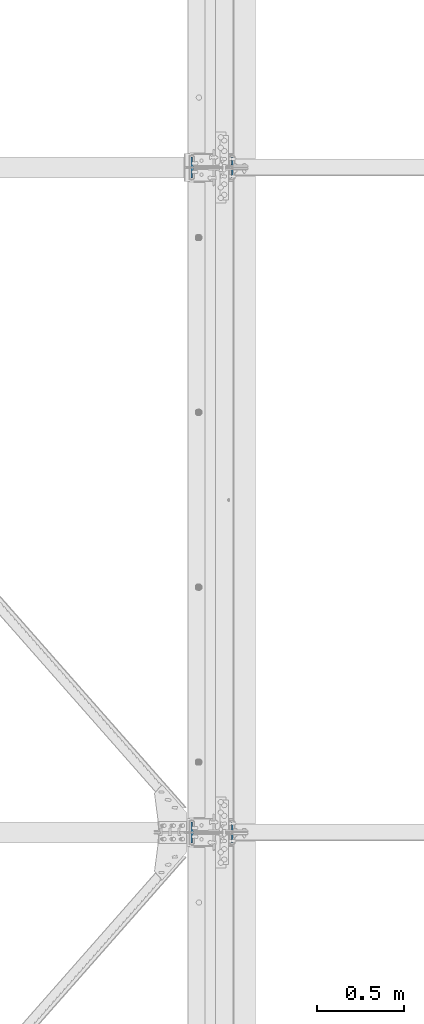
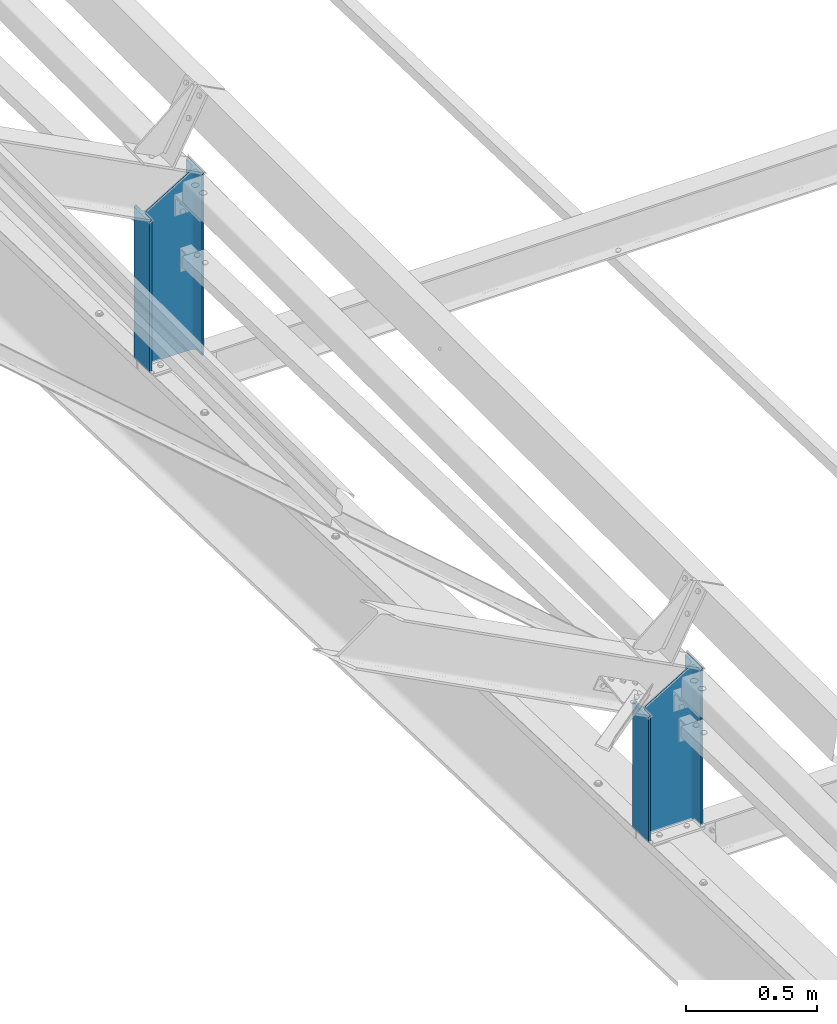
# One storey, part 31 of 496: 2 columns, 2 elements without a shape of their own.
"""IFC2X3 building model written with IfcOpenShell, lengths in millimetres."""

from ifc_helpers import new_model, si_unit, frame, origin_with_axes, origin_2d_with_axis, place, context, subcontext, project, spatial, i_section, extrude, clip, halfspace, material, type_object, element, aggregate, save


model = new_model("IFC2X3")

# Units and contexts
model_context = context("Model", 3, precision=1e-05, world=origin_with_axes())
body_context = subcontext(model_context, "Body", "Model", "MODEL_VIEW")
ifc_project = project(units=[si_unit("LENGTHUNIT", "METRE", prefix="MILLI"), si_unit("AREAUNIT", "SQUARE_METRE"), si_unit("VOLUMEUNIT", "CUBIC_METRE"), si_unit("MASSUNIT", "GRAM", prefix="KILO"), si_unit("TIMEUNIT", "SECOND"), si_unit("PLANEANGLEUNIT", "RADIAN"), si_unit("SOLIDANGLEUNIT", "STERADIAN"), si_unit("THERMODYNAMICTEMPERATUREUNIT", "DEGREE_CELSIUS"), si_unit("LUMINOUSINTENSITYUNIT", "LUMEN")], contexts=[model_context])

# Site, building, storey
site_placement = place(None, origin_with_axes())
site = spatial("IfcSite", under=ifc_project, at=site_placement, CompositionType="ELEMENT")
building_placement = place(site_placement, origin_with_axes())
building = spatial("IfcBuilding", under=site, at=building_placement, Name="Undefined", CompositionType="ELEMENT")
storey_placement = place(building_placement, origin_with_axes())
storey = spatial("IfcBuildingStorey", under=building, at=storey_placement, Name="Undefined", CompositionType="ELEMENT", Elevation=0.0)

# Assembly, column
assembly_1_placement = place(storey_placement, origin_with_axes())
assembly_1 = element("IfcElementAssembly", 1, at=assembly_1_placement, inside=storey, Name="TRAVERSE SHED", AssemblyPlace="NOTDEFINED", PredefinedType="NOTDEFINED")
ifc_material = material(Name="Undefined/S275-E28")
column_type = type_object("IfcColumnType", Name="IPE240", PredefinedType="NOTDEFINED")
column_1_placement = place(assembly_1_placement, frame((19550.0, 11400.0, 7691.74056786914), z_axis=(0.0, 0.0, 1.0), x_axis=(-1.0, 0.0, 0.0)))
column_1 = element("IfcColumn", 2, at=column_1_placement, type_object=column_type, material=ifc_material, Name="TRAVERSE SHED", ObjectType="IPE240", context=body_context, shape_type="Clipping", body=[
    clip(clip(extrude(i_section(OverallWidth=120.0, OverallDepth=240.0, WebThickness=6.199999809, FlangeThickness=9.800000191, FilletRadius=15.0, at=origin_2d_with_axis()), frame((0.0, 0.0, 860.890403333867), z_axis=(0.0, 0.0, -1.0), x_axis=(0.0, 1.0, 0.0)), (0.0, 0.0, 1.0), 926.17), halfspace(frame((-120.000000919932, 7600.0, 858.259434020199), z_axis=(0.517914825899091, 0.0, 0.855432190833332), x_axis=(0.0, 1.0, 0.0)), False)), halfspace(frame((0.0, -74.9626762494518, 7.64961930845766), z_axis=(0.0, 0.031410477145298, -0.999506569225788), x_axis=(1.0, 0.0, 0.0)), False)),
])
aggregate(assembly_1, [column_1])

assembly_2_placement = place(storey_placement, origin_with_axes())
assembly_2 = element("IfcElementAssembly", 3, at=assembly_2_placement, inside=storey, Name="TRAVERSE SHED", AssemblyPlace="NOTDEFINED", PredefinedType="NOTDEFINED")
column_2_placement = place(assembly_2_placement, frame((19550.0, 7600.0, 7811.1603785789), z_axis=(0.0, 0.0, 1.0), x_axis=(-1.0, 0.0, 0.0)))
column_2 = element("IfcColumn", 4, at=column_2_placement, type_object=column_type, material=ifc_material, Name="TRAVERSE SHED", ObjectType="IPE240", context=body_context, shape_type="Clipping", body=[
    clip(clip(extrude(i_section(OverallWidth=120.0, OverallDepth=240.0, WebThickness=6.199999809, FlangeThickness=9.800000191, FilletRadius=15.0, at=origin_2d_with_axis()), frame((0.0, 0.0, 741.470592624104), z_axis=(0.0, 0.0, -1.0), x_axis=(0.0, 1.0, 0.0)), (0.0, 0.0, 1.0), 806.75), halfspace(frame((-120.000000919932, 3800.0, 738.839623310436), z_axis=(0.517914825899091, 0.0, 0.855432190833332), x_axis=(0.0, 1.0, 0.0)), False)), halfspace(frame((0.0, -74.9626762494527, 7.65008349740219), z_axis=(0.0, 0.031410477145298, -0.999506569225788), x_axis=(1.0, 0.0, 0.0)), False)),
])
aggregate(assembly_2, [column_2])

save(model, "model.ifc")
